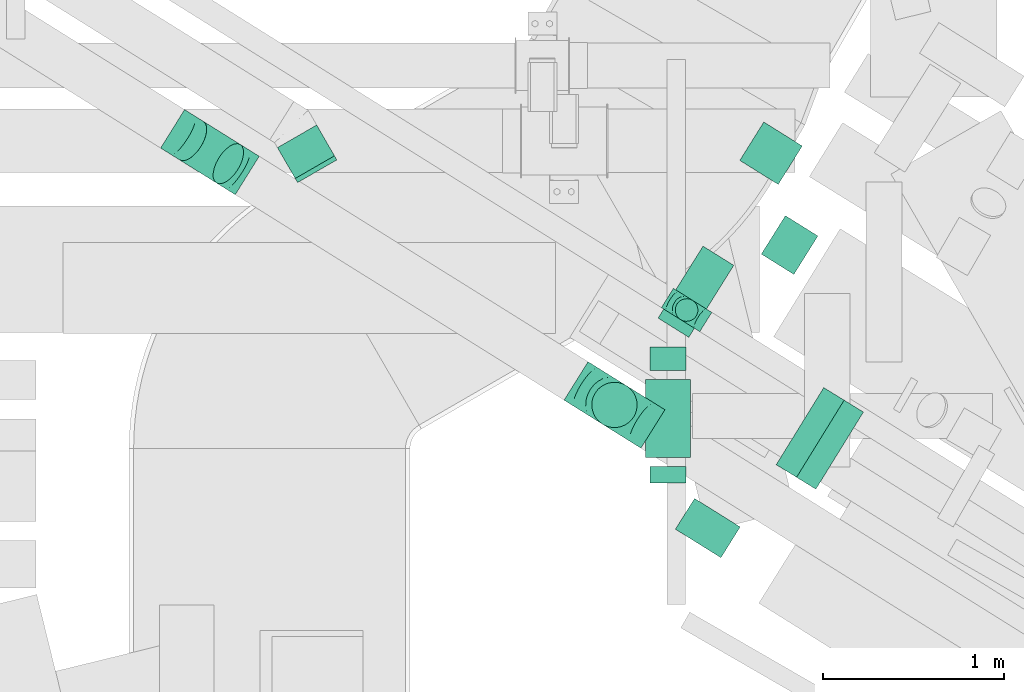
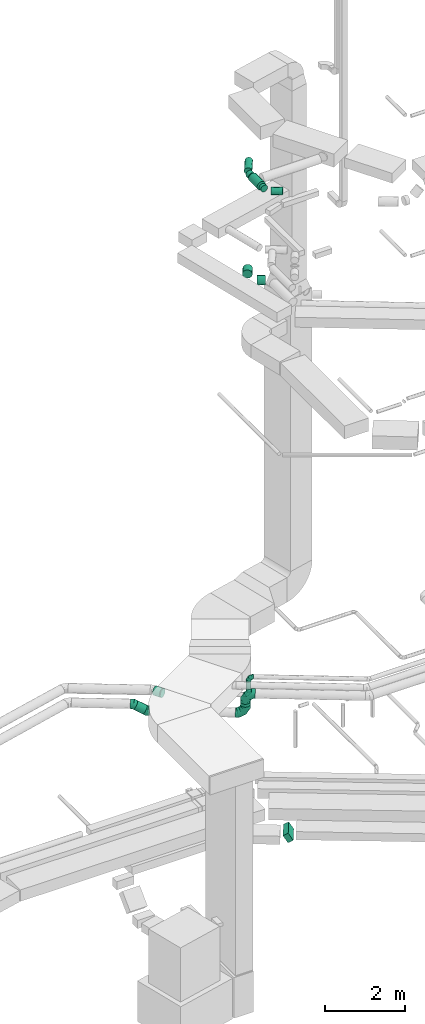
# One storey, part 88 of 337: 12 flow segments, 7 flow fittings.
"""IFC2X3 building model written with IfcOpenShell, lengths in millimetres."""

from ifc_helpers import new_model, entity, si_unit, converted_unit, derived_unit, direction, frame, frame_2d, origin, origin_2d_with_axis, place, context, subcontext, project, spatial, rectangle, circle, extrude, faceted_brep, source, transform, mapped, material, type_object, type_shapes, element, save


model = new_model("IFC2X3")

# Units and contexts
model_context = context("Model", 3, precision=0.01, world=origin(), true_north=direction((6.12303176911189e-17, 1.0)))
body_context = subcontext(model_context, "Body", "Model", "MODEL_VIEW")
ifc_project = project(units=[si_unit("LENGTHUNIT", "METRE", prefix="MILLI"), si_unit("AREAUNIT", "SQUARE_METRE"), si_unit("VOLUMEUNIT", "CUBIC_METRE"), converted_unit("PLANEANGLEUNIT", "DEGREE", entity("IfcRatioMeasure", 0.0174532925199433), si_unit("PLANEANGLEUNIT", "RADIAN"), dimensions=[0, 0, 0, 0, 0, 0, 0]), si_unit("MASSUNIT", "GRAM", prefix="KILO"), derived_unit("MASSDENSITYUNIT", [(si_unit("MASSUNIT", "GRAM", prefix="KILO"), 1), (si_unit("LENGTHUNIT", "METRE"), -3)]), derived_unit("MOMENTOFINERTIAUNIT", [(si_unit("LENGTHUNIT", "METRE"), 4)]), si_unit("TIMEUNIT", "SECOND"), si_unit("FREQUENCYUNIT", "HERTZ"), si_unit("THERMODYNAMICTEMPERATUREUNIT", "DEGREE_CELSIUS"), derived_unit("THERMALTRANSMITTANCEUNIT", [(si_unit("MASSUNIT", "GRAM", prefix="KILO"), 1), (si_unit("THERMODYNAMICTEMPERATUREUNIT", "KELVIN"), -1), (si_unit("TIMEUNIT", "SECOND"), -3)]), derived_unit("VOLUMETRICFLOWRATEUNIT", [(si_unit("LENGTHUNIT", "METRE"), 3), (si_unit("TIMEUNIT", "SECOND"), -1)]), derived_unit("MASSFLOWRATEUNIT", [(si_unit("MASSUNIT", "GRAM", prefix="KILO"), 1), (si_unit("TIMEUNIT", "SECOND"), -1)]), derived_unit("ROTATIONALFREQUENCYUNIT", [(si_unit("TIMEUNIT", "SECOND"), -1)]), si_unit("ELECTRICCURRENTUNIT", "AMPERE"), si_unit("ELECTRICVOLTAGEUNIT", "VOLT"), si_unit("POWERUNIT", "WATT"), si_unit("FORCEUNIT", "NEWTON", prefix="KILO"), si_unit("ILLUMINANCEUNIT", "LUX"), si_unit("LUMINOUSFLUXUNIT", "LUMEN"), si_unit("LUMINOUSINTENSITYUNIT", "CANDELA"), derived_unit("USERDEFINED", [(si_unit("MASSUNIT", "GRAM", prefix="KILO"), -1), (si_unit("LENGTHUNIT", "METRE"), -2), (si_unit("TIMEUNIT", "SECOND"), 3), (si_unit("LUMINOUSFLUXUNIT", "LUMEN"), 1)]), derived_unit("LINEARVELOCITYUNIT", [(si_unit("LENGTHUNIT", "METRE"), 1), (si_unit("TIMEUNIT", "SECOND"), -1)]), si_unit("PRESSUREUNIT", "PASCAL"), derived_unit("USERDEFINED", [(si_unit("LENGTHUNIT", "METRE"), -2), (si_unit("MASSUNIT", "GRAM", prefix="KILO"), 1), (si_unit("TIMEUNIT", "SECOND"), -2)]), derived_unit("LINEARFORCEUNIT", [(si_unit("MASSUNIT", "GRAM", prefix="KILO"), 1), (si_unit("LENGTHUNIT", "METRE"), 1), (si_unit("TIMEUNIT", "SECOND"), -2), (si_unit("LENGTHUNIT", "METRE"), -1)]), derived_unit("PLANARFORCEUNIT", [(si_unit("MASSUNIT", "GRAM", prefix="KILO"), 1), (si_unit("LENGTHUNIT", "METRE"), 1), (si_unit("TIMEUNIT", "SECOND"), -2), (si_unit("LENGTHUNIT", "METRE"), -2)])], contexts=[model_context])

# Site, building, storey
site_placement = place(None, origin())
site = spatial("IfcSite", under=ifc_project, at=site_placement, CompositionType="ELEMENT")
building_placement = place(site_placement, origin())
building = spatial("IfcBuilding", under=site, at=building_placement, CompositionType="ELEMENT")
storey_placement = place(building_placement, origin())
storey = spatial("IfcBuildingStorey", under=building, at=storey_placement, CompositionType="ELEMENT", Elevation=0.0)

# Flow segments
duct_segment_type_1 = type_object("IfcDuctSegmentType", PredefinedType="NOTDEFINED")
flow_segment_1_placement = place(storey_placement, frame((1795.49, 12911.63, -1071.39)))
element("IfcFlowSegment", 1, at=flow_segment_1_placement, inside=storey, type_object=duct_segment_type_1, context=body_context, shape_type="SweptSolid", body=[
    extrude(rectangle(XDim=250.000000000001, YDim=152.591585298887, at=frame_2d((0.0, 0.0), x_axis=(0.0, 1.0))), frame((109.43, 67.5, 146.4), z_axis=(0.525021739259934, 0.851088816343203, 0.0), x_axis=(-0.737064262358166, 0.454681995038198, -0.500000556542188)), (0.0, 0.0, 1.0), 499.999999999996),
])
duct_segment_type_2 = type_object("IfcDuctSegmentType", PredefinedType="NOTDEFINED")
flow_segment_2_placement = place(storey_placement, frame((1237.19, 13836.29, 3225.0)))
element("IfcFlowSegment", 2, at=flow_segment_2_placement, inside=storey, type_object=duct_segment_type_2, context=body_context, shape_type="SweptSolid", body=[
    extrude(circle(Radius=62.5, at=origin_2d_with_axis()), frame((64.06, 64.06, 0.0), z_axis=(0.0, 0.0, 1.0), x_axis=(-0.529911826412037, -0.848052743777567, 0.0)), (0.0, 0.0, 1.0), 299.999999999985),
])
flow_segment_3_placement = place(storey_placement, frame((-1516.22, 14595.29, 2931.81)))
element("IfcFlowSegment", 3, at=flow_segment_3_placement, inside=storey, type_object=duct_segment_type_2, context=body_context, shape_type="SweptSolid", body=[
    extrude(circle(Radius=125.0, at=origin_2d_with_axis()), frame((288.86, 112.41, 110.46), z_axis=(-0.73858736325214, 0.461511599953564, 0.491422170798747), x_axis=(0.529911826412037, 0.848052743777567, 0.0)), (0.0, 0.0, 1.0), 275.650459895627),
])
flow_segment_4_placement = place(storey_placement, frame((-958.11, 14624.52, 3273.4)))
element("IfcFlowSegment", 4, at=flow_segment_4_placement, inside=storey, type_object=duct_segment_type_2, context=body_context, shape_type="SweptSolid", body=[
    extrude(circle(Radius=125.0, at=origin_2d_with_axis()), frame((208.02, 64.1, 126.6), z_axis=(-0.50000000000098, 0.866025403783873, 0.0), x_axis=(-0.866025403783873, -0.50000000000098, 0.0)), (0.0, 0.0, 1.0), 196.352513184056),
])
flow_segment_5_placement = place(storey_placement, frame((1096.43, 12945.25, 19048.4)))
element("IfcFlowSegment", 5, at=flow_segment_5_placement, inside=storey, type_object=duct_segment_type_2, context=body_context, shape_type="SweptSolid", body=[
    extrude(circle(Radius=100.0, at=origin_2d_with_axis()), frame((101.6, 0.0, 101.6), z_axis=(0.0, 1.0, 0.0), x_axis=(-1.0, 0.0, 0.0)), (0.0, 0.0, 1.0), 90.6991860687101),
])
flow_segment_6_placement = place(storey_placement, frame((1237.46, 12531.96, 19048.4)))
element("IfcFlowSegment", 6, at=flow_segment_6_placement, inside=storey, type_object=duct_segment_type_2, context=body_context, shape_type="SweptSolid", body=[
    extrude(circle(Radius=100.0, at=origin_2d_with_axis()), frame((54.59, 243.67, 101.6), z_axis=(0.848052743777581, -0.529911826412015, 0.0), x_axis=(-0.529911826412015, -0.848052743777581, 0.0)), (0.0, 0.0, 1.0), 296.789772620935),
])
flow_segment_7_placement = place(storey_placement, frame((1071.43, 13085.95, 19023.4)))
element("IfcFlowSegment", 7, at=flow_segment_7_placement, inside=storey, type_object=duct_segment_type_2, context=body_context, shape_type="SweptSolid", body=[
    extrude(circle(Radius=125.0, at=origin_2d_with_axis()), frame((126.6, 0.0, 126.6), z_axis=(0.0, 1.0, 0.0), x_axis=(1.0, 0.0, 0.0)), (0.0, 0.0, 1.0), 429.999999999969),
])
flow_segment_8_placement = place(storey_placement, frame((1096.43, 13565.95, 19048.4)))
element("IfcFlowSegment", 8, at=flow_segment_8_placement, inside=storey, type_object=duct_segment_type_2, context=body_context, shape_type="SweptSolid", body=[
    extrude(circle(Radius=100.0, at=origin_2d_with_axis()), frame((101.6, 0.0, 101.6), z_axis=(0.0, 1.0, 0.0), x_axis=(1.0, 0.0, 0.0)), (0.0, 0.0, 1.0), 130.658272842002),
])
flow_segment_9_placement = place(storey_placement, frame((1142.02, 13748.0, 19048.4)))
element("IfcFlowSegment", 9, at=flow_segment_9_placement, inside=storey, type_object=duct_segment_type_2, context=body_context, shape_type="SweptSolid", body=[
    extrude(circle(Radius=100.0, at=origin_2d_with_axis()), frame((86.4, 54.59, 101.6), z_axis=(0.529911826412034, 0.848052743777569, 0.0), x_axis=(0.848052743777569, -0.529911826412034, 0.0)), (0.0, 0.0, 1.0), 468.302730412856),
])
flow_segment_10_placement = place(storey_placement, frame((1711.98, 14095.08, 15198.4)))
element("IfcFlowSegment", 10, at=flow_segment_10_placement, inside=storey, type_object=duct_segment_type_2, context=body_context, shape_type="SweptSolid", body=[
    extrude(circle(Radius=125.0, at=origin_2d_with_axis()), frame((67.92, 219.79, 126.6), z_axis=(0.847641877077062, -0.530568796882436, 0.0), x_axis=(0.530568796882436, 0.847641877077062, 0.0)), (0.0, 0.0, 1.0), 211.547896637581),
])
flow_segment_11_placement = place(storey_placement, frame((1593.08, 14591.51, 15198.4)))
element("IfcFlowSegment", 11, at=flow_segment_11_placement, inside=storey, type_object=duct_segment_type_2, context=body_context, shape_type="SweptSolid", body=[
    extrude(circle(Radius=125.0, at=origin_2d_with_axis()), frame((107.55, 67.92, 126.6), z_axis=(0.530568796882462, 0.847641877077045, 0.0), x_axis=(0.847641877077045, -0.530568796882462, 0.0)), (0.0, 0.0, 1.0), 249.999999999994),
])
flow_segment_12_placement = place(storey_placement, frame((776.55, 13249.97, 3260.0)))
element("IfcFlowSegment", 12, at=flow_segment_12_placement, inside=storey, type_object=duct_segment_type_2, context=body_context, shape_type="SweptSolid", body=[
    extrude(circle(Radius=125.0, at=origin_2d_with_axis()), frame((126.52, 126.52, 0.0), z_axis=(0.0, 0.0, 1.0), x_axis=(-0.529911826412039, -0.848052743777566, 0.0)), (0.0, 0.0, 1.0), 90.0000000000337),
])

# Flow fittings
ifc_material = material()
duct_fitting_type_1 = type_object("IfcDuctFittingType", PredefinedType="NOTDEFINED", material=ifc_material)
shared_shape_1 = source(origin(), body_context, "Body", "Brep", [
    faceted_brep([(-250.0, 0.0, -125.0), (-250.0, -32.35, -120.74), (-250.0, -62.5, -108.25), (-250.0, -88.39, -88.39), (-250.0, -108.25, -62.5), (-250.0, -120.74, -32.35), (-250.0, -125.0, 0.0), (-250.0, -120.74, 32.35), (-250.0, -108.25, 62.5), (-250.0, -88.39, 88.39), (-250.0, -62.5, 108.25), (-250.0, -32.35, 120.74), (-250.0, 0.0, 125.0), (-250.0, 32.35, 120.74), (-250.0, 62.5, 108.25), (-250.0, 88.39, 88.39), (-250.0, 108.25, 62.5), (-250.0, 120.74, 32.35), (-250.0, 125.0, 0.0), (-250.0, 120.74, -32.35), (-250.0, 108.25, -62.5), (-250.0, 88.39, -88.39), (-250.0, 62.5, -108.25), (-250.0, 32.35, -120.74), (-191.68, 32.35, 120.74), (-199.76, 62.5, 108.25), (-183.01, 0.0, 125.0), (-206.7, 88.39, 88.39), (-215.37, 120.74, 32.35), (-216.51, 125.0, 0.0), (-212.02, 108.25, 62.5), (-212.02, 108.25, -62.5), (-206.7, 88.39, -88.39), (-215.37, 120.74, -32.35), (-191.68, 32.35, -120.74), (-183.01, 0.0, -125.0), (-199.76, 62.5, -108.25), (-174.34, -32.35, -120.74), (-166.27, -62.5, -108.25), (-159.33, -88.39, -88.39), (-154.01, -108.25, -62.5), (-150.66, -120.74, -32.35), (-149.52, -125.0, 0.0), (-150.66, -120.74, 32.35), (-154.01, -108.25, 62.5), (-159.33, -88.39, 88.39), (-166.27, -62.5, 108.25), (-174.34, -32.35, 120.74), (-90.67, 90.67, 120.74), (-112.74, 112.74, 108.25), (-66.99, 66.99, 125.0), (-131.69, 131.69, 88.39), (-146.23, 146.23, 62.5), (-155.38, 155.38, 32.35), (-158.49, 158.49, 0.0), (-155.38, 155.38, -32.35), (-146.23, 146.23, -62.5), (-131.69, 131.69, -88.39), (-90.67, 90.67, -120.74), (-66.99, 66.99, -125.0), (-112.74, 112.74, -108.25), (-43.3, 43.3, -120.74), (-21.23, 21.23, -108.25), (-2.28, 2.28, -88.39), (12.26, -12.26, -62.5), (21.4, -21.4, -32.35), (24.52, -24.52, 0.0), (21.4, -21.4, 32.35), (12.26, -12.26, 62.5), (-2.28, 2.28, 88.39), (-21.23, 21.23, 108.25), (-43.3, 43.3, 120.74), (-32.35, 191.68, 120.74), (-62.5, 199.76, 108.25), (0.0, 183.01, 125.0), (-88.39, 206.7, 88.39), (-108.25, 212.02, 62.5), (-120.74, 215.37, 32.35), (-125.0, 216.51, 0.0), (-120.74, 215.37, -32.35), (-108.25, 212.02, -62.5), (-88.39, 206.7, -88.39), (-32.35, 191.68, -120.74), (0.0, 183.01, -125.0), (-62.5, 199.76, -108.25), (32.35, 174.34, -120.74), (62.5, 166.27, -108.25), (88.39, 159.33, -88.39), (108.25, 154.01, -62.5), (120.74, 150.66, -32.35), (125.0, 149.52, 0.0), (120.74, 150.66, 32.35), (108.25, 154.01, 62.5), (88.39, 159.33, 88.39), (62.5, 166.27, 108.25), (32.35, 174.34, 120.74), (-32.35, 250.0, -120.74), (-62.5, 250.0, -108.25), (-88.39, 250.0, -88.39), (-108.25, 250.0, -62.5), (-120.74, 250.0, -32.35), (-125.0, 250.0, 0.0), (-120.74, 250.0, 32.35), (-108.25, 250.0, 62.5), (-88.39, 250.0, 88.39), (-62.5, 250.0, 108.25), (-32.35, 250.0, 120.74), (0.0, 250.0, 125.0), (32.35, 250.0, 120.74), (62.5, 250.0, 108.25), (88.39, 250.0, 88.39), (108.25, 250.0, 62.5), (120.74, 250.0, 32.35), (125.0, 250.0, 0.0), (120.74, 250.0, -32.35), (108.25, 250.0, -62.5), (88.39, 250.0, -88.39), (62.5, 250.0, -108.25), (32.35, 250.0, -120.74), (0.0, 250.0, -125.0)], [[[0, 1, 2, 3, 4, 5, 6, 7, 8, 9, 10, 11, 12, 13, 14, 15, 16, 17, 18, 19, 20, 21, 22, 23]], [[24, 25, 14, 13]], [[26, 24, 13, 12]], [[14, 25, 27, 15]], [[28, 29, 18, 17]], [[30, 28, 17, 16]], [[15, 27, 30, 16]], [[20, 31, 32, 21]], [[33, 31, 20, 19]], [[18, 29, 33, 19]], [[34, 35, 0, 23]], [[36, 34, 23, 22]], [[21, 32, 36, 22]], [[1, 0, 35, 37]], [[2, 1, 37, 38]], [[38, 39, 3, 2]], [[5, 4, 40, 41]], [[6, 5, 41, 42]], [[39, 40, 4, 3]], [[6, 42, 43, 7]], [[7, 43, 44, 8]], [[8, 44, 45, 9]], [[9, 45, 46, 10]], [[10, 46, 47, 11]], [[26, 12, 11, 47]], [[48, 49, 25, 24]], [[50, 48, 24, 26]], [[27, 25, 49, 51]], [[52, 53, 28, 30]], [[51, 52, 30, 27]], [[29, 28, 53, 54]], [[55, 56, 31, 33]], [[54, 55, 33, 29]], [[32, 31, 56, 57]], [[58, 59, 35, 34]], [[60, 58, 34, 36]], [[57, 60, 36, 32]], [[37, 35, 59, 61]], [[38, 37, 61, 62]], [[39, 38, 62, 63]], [[41, 40, 64, 65]], [[42, 41, 65, 66]], [[63, 64, 40, 39]], [[43, 42, 66, 67]], [[44, 43, 67, 68]], [[68, 69, 45, 44]], [[46, 45, 69, 70]], [[47, 46, 70, 71]], [[26, 47, 71, 50]], [[72, 73, 49, 48]], [[74, 72, 48, 50]], [[51, 49, 73, 75]], [[76, 77, 53, 52]], [[75, 76, 52, 51]], [[54, 53, 77, 78]], [[79, 80, 56, 55]], [[78, 79, 55, 54]], [[57, 56, 80, 81]], [[82, 83, 59, 58]], [[84, 82, 58, 60]], [[81, 84, 60, 57]], [[61, 59, 83, 85]], [[62, 61, 85, 86]], [[63, 62, 86, 87]], [[65, 64, 88, 89]], [[66, 65, 89, 90]], [[87, 88, 64, 63]], [[67, 66, 90, 91]], [[68, 67, 91, 92]], [[92, 93, 69, 68]], [[70, 69, 93, 94]], [[71, 70, 94, 95]], [[50, 71, 95, 74]], [[96, 97, 98, 99, 100, 101, 102, 103, 104, 105, 106, 107, 108, 109, 110, 111, 112, 113, 114, 115, 116, 117, 118, 119]], [[72, 74, 107, 106]], [[73, 72, 106, 105]], [[75, 73, 105, 104]], [[77, 76, 103, 102]], [[78, 77, 102, 101]], [[75, 104, 103, 76]], [[78, 101, 100, 79]], [[79, 100, 99, 80]], [[80, 99, 98, 81]], [[84, 97, 96, 82]], [[82, 96, 119, 83]], [[84, 81, 98, 97]], [[83, 119, 118, 85]], [[85, 118, 117, 86]], [[116, 87, 86, 117]], [[88, 115, 114, 89]], [[89, 114, 113, 90]], [[115, 88, 87, 116]], [[91, 90, 113, 112]], [[92, 91, 112, 111]], [[111, 110, 93, 92]], [[95, 94, 109, 108]], [[74, 95, 108, 107]], [[110, 109, 94, 93]]]),
])
type_shapes(duct_fitting_type_1, [shared_shape_1])
for number, where, z_axis, x_axis in (
    (13, (903.07, 13376.49, 3600.0), (-0.529911826412037, -0.848052743777567, 0.0), (-0.848052743777567, 0.529911826412037, 0.0)),
    (14, (903.07, 13376.49, 3010.0), (0.529911826412029, 0.848052743777572, 0.0), (0.0, 0.0, -1.0)),
):
    element("IfcFlowFitting", number, at=place(storey_placement, frame(where, z_axis=z_axis, x_axis=x_axis)), inside=storey, type_object=duct_fitting_type_1, material=ifc_material, context=body_context, shape_type="MappedRepresentation", body=[
        mapped(shared_shape_1, transform((0.0, 0.0, 0.0), scale=1.0)),
    ])
duct_fitting_type_2 = type_object("IfcDuctFittingType", PredefinedType="NOTDEFINED", material=ifc_material)
shared_shape_2 = source(origin(), body_context, "Body", "Brep", [
    faceted_brep([(20.0, 0.0, -125.0), (20.0, 32.35, -120.74), (20.0, 62.5, -108.25), (20.0, 88.39, -88.39), (20.0, 108.25, -62.5), (20.0, 120.74, -32.35), (20.0, 125.0, 0.0), (20.0, 120.74, 32.35), (20.0, 108.25, 62.5), (20.0, 88.39, 88.39), (20.0, 62.5, 108.25), (20.0, 32.35, 120.74), (20.0, 0.0, 125.0), (20.0, -32.35, 120.74), (20.0, -62.5, 108.25), (20.0, -88.39, 88.39), (20.0, -108.25, 62.5), (20.0, -120.74, 32.35), (20.0, -125.0, 0.0), (20.0, -120.74, -32.35), (20.0, -108.25, -62.5), (20.0, -88.39, -88.39), (20.0, -62.5, -108.25), (20.0, -32.35, -120.74), (0.0, 0.0, 125.0), (-6.1, 0.0, 125.0), (-6.1, -32.35, 120.74), (0.0, -32.35, 120.74), (-6.1, -62.5, 108.25), (0.0, -62.5, 108.25), (0.0, -88.39, 88.39), (-6.1, -88.39, 88.39), (0.0, -108.25, 62.5), (-6.1, -108.25, 62.5), (-6.1, -120.74, 32.35), (0.0, -120.74, 32.35), (-6.1, -125.0, 0.0), (0.0, -125.0, 0.0), (-6.1, -120.74, -32.35), (0.0, -120.74, -32.35), (-6.1, -108.25, -62.5), (0.0, -108.25, -62.5), (0.0, -88.39, -88.39), (-6.1, -88.39, -88.39), (0.0, -62.5, -108.25), (-6.1, -62.5, -108.25), (-6.1, -32.35, -120.74), (0.0, -32.35, -120.74), (-6.1, 0.0, -125.0), (0.0, 0.0, -125.0), (-6.1, 32.35, -120.74), (0.0, 32.35, -120.74), (-6.1, 62.5, -108.25), (0.0, 62.5, -108.25), (0.0, 88.39, -88.39), (-6.1, 88.39, -88.39), (0.0, 108.25, -62.5), (-6.1, 108.25, -62.5), (-6.1, 120.74, -32.35), (0.0, 120.74, -32.35), (-6.1, 125.0, 0.0), (0.0, 125.0, 0.0), (-6.1, 120.74, 32.35), (0.0, 120.74, 32.35), (-6.1, 108.25, 62.5), (0.0, 108.25, 62.5), (0.0, 88.39, 88.39), (-6.1, 88.39, 88.39), (0.0, 62.5, 108.25), (-6.1, 62.5, 108.25), (-6.1, 32.35, 120.74), (0.0, 32.35, 120.74)], [[[0, 1, 2, 3, 4, 5, 6, 7, 8, 9, 10, 11, 12, 13, 14, 15, 16, 17, 18, 19, 20, 21, 22, 23]], [[13, 12, 24, 25, 26, 27]], [[14, 13, 27, 26, 28, 29]], [[30, 15, 14, 29, 28, 31]], [[17, 16, 32, 33, 34, 35]], [[18, 17, 35, 34, 36, 37]], [[32, 16, 15, 30, 31, 33]], [[19, 18, 37, 36, 38, 39]], [[20, 19, 39, 38, 40, 41]], [[42, 21, 20, 41, 40, 43]], [[23, 22, 44, 45, 46, 47]], [[0, 23, 47, 46, 48, 49]], [[44, 22, 21, 42, 43, 45]], [[1, 0, 49, 48, 50, 51]], [[2, 1, 51, 50, 52, 53]], [[54, 3, 2, 53, 52, 55]], [[5, 4, 56, 57, 58, 59]], [[6, 5, 59, 58, 60, 61]], [[56, 4, 3, 54, 55, 57]], [[7, 6, 61, 60, 62, 63]], [[8, 7, 63, 62, 64, 65]], [[66, 9, 8, 65, 64, 67]], [[11, 10, 68, 69, 70, 71]], [[12, 11, 71, 70, 25, 24]], [[68, 10, 9, 66, 67, 69]], [[46, 45, 43, 40, 38, 36, 34, 33, 31, 28, 26, 25, 70, 69, 67, 64, 62, 60, 58, 57, 55, 52, 50, 48]]]),
])
type_shapes(duct_fitting_type_2, [shared_shape_2])
flow_fitting_placement = place(storey_placement, frame((-740.08, 14671.3, 3400.0), z_axis=(0.0, 0.0, -1.0), x_axis=(-0.500000000000015, 0.86602540378443, 0.0)))
element("IfcFlowFitting", 15, at=flow_fitting_placement, inside=storey, type_object=duct_fitting_type_2, material=ifc_material, context=body_context, shape_type="MappedRepresentation", body=[
    mapped(shared_shape_2, transform((0.0, 0.0, 0.0), scale=1.0)),
])
duct_fitting_type_3 = type_object("IfcDuctFittingType", PredefinedType="NOTDEFINED", material=ifc_material)
shared_shape_3 = source(origin(), body_context, "Body", "Brep", [
    faceted_brep([(-125.0, 0.0, -62.5), (-125.0, -16.18, -60.37), (-125.0, -31.25, -54.13), (-125.0, -44.19, -44.19), (-125.0, -54.13, -31.25), (-125.0, -60.37, -16.18), (-125.0, -62.5, 0.0), (-125.0, -60.37, 16.18), (-125.0, -54.13, 31.25), (-125.0, -44.19, 44.19), (-125.0, -31.25, 54.13), (-125.0, -16.18, 60.37), (-125.0, 0.0, 62.5), (-125.0, 16.18, 60.37), (-125.0, 31.25, 54.13), (-125.0, 44.19, 44.19), (-125.0, 54.13, 31.25), (-125.0, 60.37, 16.18), (-125.0, 62.5, 0.0), (-125.0, 60.37, -16.18), (-125.0, 54.13, -31.25), (-125.0, 44.19, -44.19), (-125.0, 31.25, -54.13), (-125.0, 16.18, -60.37), (-95.84, 16.18, 60.37), (-99.88, 31.25, 54.13), (-91.51, 0.0, 62.5), (-103.35, 44.19, 44.19), (-107.68, 60.37, 16.18), (-108.25, 62.5, 0.0), (-106.01, 54.13, 31.25), (-106.01, 54.13, -31.25), (-103.35, 44.19, -44.19), (-107.68, 60.37, -16.18), (-95.84, 16.18, -60.37), (-91.51, 0.0, -62.5), (-99.88, 31.25, -54.13), (-87.17, -16.18, -60.37), (-83.13, -31.25, -54.13), (-79.66, -44.19, -44.19), (-77.0, -54.13, -31.25), (-75.33, -60.37, -16.18), (-74.76, -62.5, 0.0), (-75.33, -60.37, 16.18), (-77.0, -54.13, 31.25), (-79.66, -44.19, 44.19), (-83.13, -31.25, 54.13), (-87.17, -16.18, 60.37), (-45.34, 45.34, 60.37), (-56.37, 56.37, 54.13), (-33.49, 33.49, 62.5), (-65.85, 65.85, 44.19), (-73.12, 73.12, 31.25), (-77.69, 77.69, 16.18), (-79.25, 79.25, 0.0), (-77.69, 77.69, -16.18), (-73.12, 73.12, -31.25), (-65.85, 65.85, -44.19), (-45.34, 45.34, -60.37), (-33.49, 33.49, -62.5), (-56.37, 56.37, -54.13), (-21.65, 21.65, -60.37), (-10.62, 10.62, -54.13), (-1.14, 1.14, -44.19), (6.13, -6.13, -31.25), (10.7, -10.7, -16.18), (12.26, -12.26, 0.0), (10.7, -10.7, 16.18), (6.13, -6.13, 31.25), (-1.14, 1.14, 44.19), (-10.62, 10.62, 54.13), (-21.65, 21.65, 60.37), (-16.18, 95.84, 60.37), (-31.25, 99.88, 54.13), (0.0, 91.51, 62.5), (-44.19, 103.35, 44.19), (-54.13, 106.01, 31.25), (-60.37, 107.68, 16.18), (-62.5, 108.25, 0.0), (-60.37, 107.68, -16.18), (-54.13, 106.01, -31.25), (-44.19, 103.35, -44.19), (-16.18, 95.84, -60.37), (0.0, 91.51, -62.5), (-31.25, 99.88, -54.13), (16.18, 87.17, -60.37), (31.25, 83.13, -54.13), (44.19, 79.66, -44.19), (54.13, 77.0, -31.25), (60.37, 75.33, -16.18), (62.5, 74.76, 0.0), (60.37, 75.33, 16.18), (54.13, 77.0, 31.25), (44.19, 79.66, 44.19), (31.25, 83.13, 54.13), (16.18, 87.17, 60.37), (-16.18, 125.0, -60.37), (-31.25, 125.0, -54.13), (-44.19, 125.0, -44.19), (-54.13, 125.0, -31.25), (-60.37, 125.0, -16.18), (-62.5, 125.0, 0.0), (-60.37, 125.0, 16.18), (-54.13, 125.0, 31.25), (-44.19, 125.0, 44.19), (-31.25, 125.0, 54.13), (-16.18, 125.0, 60.37), (0.0, 125.0, 62.5), (16.18, 125.0, 60.37), (31.25, 125.0, 54.13), (44.19, 125.0, 44.19), (54.13, 125.0, 31.25), (60.37, 125.0, 16.18), (62.5, 125.0, 0.0), (60.37, 125.0, -16.18), (54.13, 125.0, -31.25), (44.19, 125.0, -44.19), (31.25, 125.0, -54.13), (16.18, 125.0, -60.37), (0.0, 125.0, -62.5)], [[[0, 1, 2, 3, 4, 5, 6, 7, 8, 9, 10, 11, 12, 13, 14, 15, 16, 17, 18, 19, 20, 21, 22, 23]], [[24, 25, 14, 13]], [[26, 24, 13, 12]], [[14, 25, 27, 15]], [[28, 29, 18, 17]], [[30, 28, 17, 16]], [[15, 27, 30, 16]], [[20, 31, 32, 21]], [[33, 31, 20, 19]], [[18, 29, 33, 19]], [[34, 35, 0, 23]], [[36, 34, 23, 22]], [[21, 32, 36, 22]], [[1, 0, 35, 37]], [[2, 1, 37, 38]], [[38, 39, 3, 2]], [[5, 4, 40, 41]], [[6, 5, 41, 42]], [[39, 40, 4, 3]], [[6, 42, 43, 7]], [[7, 43, 44, 8]], [[45, 9, 8, 44]], [[9, 45, 46, 10]], [[10, 46, 47, 11]], [[26, 12, 11, 47]], [[48, 49, 25, 24]], [[50, 48, 24, 26]], [[27, 25, 49, 51]], [[52, 53, 28, 30]], [[51, 52, 30, 27]], [[29, 28, 53, 54]], [[55, 56, 31, 33]], [[54, 55, 33, 29]], [[57, 32, 31, 56]], [[58, 59, 35, 34]], [[60, 58, 34, 36]], [[57, 60, 36, 32]], [[37, 35, 59, 61]], [[38, 37, 61, 62]], [[39, 38, 62, 63]], [[41, 40, 64, 65]], [[42, 41, 65, 66]], [[63, 64, 40, 39]], [[43, 42, 66, 67]], [[44, 43, 67, 68]], [[68, 69, 45, 44]], [[46, 45, 69, 70]], [[47, 46, 70, 71]], [[26, 47, 71, 50]], [[72, 73, 49, 48]], [[74, 72, 48, 50]], [[51, 49, 73, 75]], [[76, 77, 53, 52]], [[75, 76, 52, 51]], [[54, 53, 77, 78]], [[79, 80, 56, 55]], [[78, 79, 55, 54]], [[81, 57, 56, 80]], [[82, 83, 59, 58]], [[84, 82, 58, 60]], [[81, 84, 60, 57]], [[61, 59, 83, 85]], [[62, 61, 85, 86]], [[63, 62, 86, 87]], [[65, 64, 88, 89]], [[66, 65, 89, 90]], [[87, 88, 64, 63]], [[67, 66, 90, 91]], [[68, 67, 91, 92]], [[92, 93, 69, 68]], [[70, 69, 93, 94]], [[71, 70, 94, 95]], [[50, 71, 95, 74]], [[96, 97, 98, 99, 100, 101, 102, 103, 104, 105, 106, 107, 108, 109, 110, 111, 112, 113, 114, 115, 116, 117, 118, 119]], [[72, 74, 107, 106]], [[73, 72, 106, 105]], [[75, 73, 105, 104]], [[77, 76, 103, 102]], [[78, 77, 102, 101]], [[75, 104, 103, 76]], [[78, 101, 100, 79]], [[79, 100, 99, 80]], [[80, 99, 98, 81]], [[96, 119, 83, 82]], [[97, 96, 82, 84]], [[84, 81, 98, 97]], [[83, 119, 118, 85]], [[85, 118, 117, 86]], [[116, 87, 86, 117]], [[88, 115, 114, 89]], [[89, 114, 113, 90]], [[115, 88, 87, 116]], [[91, 90, 113, 112]], [[92, 91, 112, 111]], [[111, 110, 93, 92]], [[95, 94, 109, 108]], [[74, 95, 108, 107]], [[110, 109, 94, 93]]]),
])
type_shapes(duct_fitting_type_3, [shared_shape_3])
for number, where, z_axis, x_axis in (
    (16, (1301.25, 13900.35, 3100.0), (-0.529911826412034, -0.848052743777569, 0.0), (0.848052743777569, -0.529911826412034, 0.0)),
    (17, (1301.25, 13900.35, 3650.0), (0.529911826412035, 0.848052743777568, 0.0), (0.0, 0.0, 1.0)),
):
    element("IfcFlowFitting", number, at=place(storey_placement, frame(where, z_axis=z_axis, x_axis=x_axis)), inside=storey, type_object=duct_fitting_type_3, material=ifc_material, context=body_context, shape_type="MappedRepresentation", body=[
        mapped(shared_shape_3, transform((0.0, 0.0, 0.0), scale=1.0)),
    ])
duct_fitting_type_4 = type_object("IfcDuctFittingType", PredefinedType="NOTDEFINED", material=ifc_material)
shared_shape_4 = source(origin(), body_context, "Body", "Brep", [
    faceted_brep([(-65.67, 0.0, -125.0), (-65.67, -32.35, -120.74), (-65.67, -62.5, -108.25), (-65.67, -88.39, -88.39), (-65.67, -108.25, -62.5), (-65.67, -120.74, -32.35), (-65.67, -125.0, 0.0), (-65.67, -120.74, 32.35), (-65.67, -108.25, 62.5), (-65.67, -88.39, 88.39), (-65.67, -62.5, 108.25), (-65.67, -32.35, 120.74), (-65.67, 0.0, 125.0), (-65.67, 32.35, 120.74), (-65.67, 62.5, 108.25), (-65.67, 88.39, 88.39), (-65.67, 108.25, 62.5), (-65.67, 120.74, 32.35), (-65.67, 125.0, 0.0), (-65.67, 120.74, -32.35), (-65.67, 108.25, -62.5), (-65.67, 88.39, -88.39), (-65.67, 62.5, -108.25), (-65.67, 32.35, -120.74), (-8.5, 32.35, 120.74), (-16.42, 62.5, 108.25), (0.0, 0.0, 125.0), (-23.22, 88.39, 88.39), (-31.71, 120.74, 32.35), (-32.83, 125.0, 0.0), (-28.43, 108.25, 62.5), (-28.43, 108.25, -62.5), (-23.22, 88.39, -88.39), (-31.71, 120.74, -32.35), (-8.5, 32.35, -120.74), (0.0, 0.0, -125.0), (-16.42, 62.5, -108.25), (8.5, -32.35, -120.74), (16.42, -62.5, -108.25), (23.22, -88.39, -88.39), (28.43, -108.25, -62.5), (31.71, -120.74, -32.35), (32.83, -125.0, 0.0), (31.71, -120.74, 32.35), (28.43, -108.25, 62.5), (23.22, -88.39, 88.39), (16.42, -62.5, 108.25), (8.5, -32.35, 120.74), (57.19, 32.27, 125.0), (41.29, 60.45, 120.74), (26.48, 86.7, 108.25), (13.75, 109.25, 88.39), (3.99, 126.55, 62.5), (-2.14, 137.43, 32.35), (-4.24, 141.13, 0.0), (-2.14, 137.43, -32.35), (3.99, 126.55, -62.5), (13.75, 109.25, -88.39), (26.48, 86.7, -108.25), (41.29, 60.45, -120.74), (57.19, 32.27, -125.0), (73.09, 4.09, -120.74), (87.9, -22.16, -108.25), (100.63, -44.71, -88.39), (110.39, -62.01, -62.5), (116.52, -72.89, -32.35), (118.62, -76.6, 0.0), (116.52, -72.89, 32.35), (110.39, -62.01, 62.5), (100.63, -44.71, 88.39), (87.9, -22.16, 108.25), (73.09, 4.09, 120.74)], [[[0, 1, 2, 3, 4, 5, 6, 7, 8, 9, 10, 11, 12, 13, 14, 15, 16, 17, 18, 19, 20, 21, 22, 23]], [[24, 25, 14, 13]], [[26, 24, 13, 12]], [[14, 25, 27, 15]], [[28, 29, 18, 17]], [[30, 28, 17, 16]], [[16, 15, 27, 30]], [[20, 31, 32, 21]], [[33, 31, 20, 19]], [[18, 29, 33, 19]], [[34, 35, 0, 23]], [[36, 34, 23, 22]], [[21, 32, 36, 22]], [[1, 0, 35, 37]], [[2, 1, 37, 38]], [[3, 2, 38, 39]], [[5, 4, 40, 41]], [[6, 5, 41, 42]], [[39, 40, 4, 3]], [[6, 42, 43, 7]], [[7, 43, 44, 8]], [[8, 44, 45, 9]], [[9, 45, 46, 10]], [[10, 46, 47, 11]], [[26, 12, 11, 47]], [[24, 26, 48, 49]], [[25, 24, 49, 50]], [[27, 25, 50, 51]], [[28, 30, 52, 53]], [[29, 28, 53, 54]], [[27, 51, 52, 30]], [[29, 54, 55, 33]], [[33, 55, 56, 31]], [[31, 56, 57, 32]], [[36, 58, 59, 34]], [[34, 59, 60, 35]], [[36, 32, 57, 58]], [[61, 62, 38, 37]], [[60, 61, 37, 35]], [[63, 39, 38, 62]], [[40, 64, 65, 41]], [[41, 65, 66, 42]], [[64, 40, 39, 63]], [[43, 42, 66, 67]], [[44, 43, 67, 68]], [[68, 69, 45, 44]], [[47, 46, 70, 71]], [[26, 47, 71, 48]], [[69, 70, 46, 45]], [[59, 58, 57, 56, 55, 54, 53, 52, 51, 50, 49, 48, 71, 70, 69, 68, 67, 66, 65, 64, 63, 62, 61, 60]]]),
])
type_shapes(duct_fitting_type_4, [shared_shape_4])
for number, where, z_axis, x_axis in (
    (18, (-1479.45, 14865.23, 3210.0), (0.529911826412031, 0.848052743777571, 0.0), (0.848052743777571, -0.529911826412031, 0.0)),
    (19, (-1178.86, 14677.4, 3010.0), (-0.529911826412029, -0.848052743777572, 0.0), (0.73858736325214, -0.461511599953564, -0.491422170798747)),
):
    element("IfcFlowFitting", number, at=place(storey_placement, frame(where, z_axis=z_axis, x_axis=x_axis)), inside=storey, type_object=duct_fitting_type_4, material=ifc_material, context=body_context, shape_type="MappedRepresentation", body=[
        mapped(shared_shape_4, transform((0.0, 0.0, 0.0), scale=1.0)),
    ])

save(model, "model.ifc")
